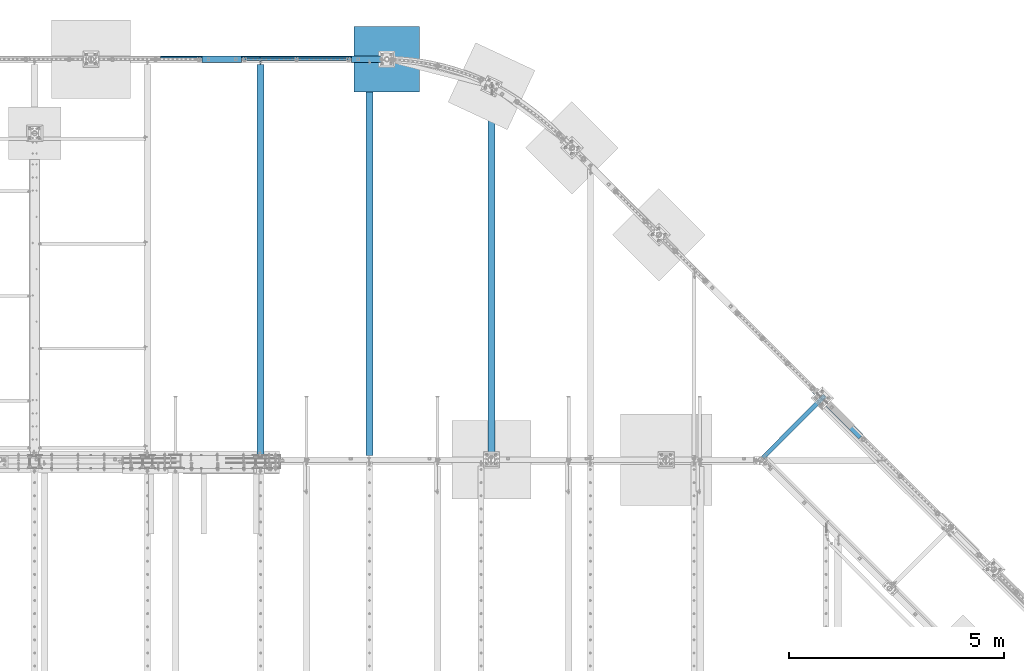
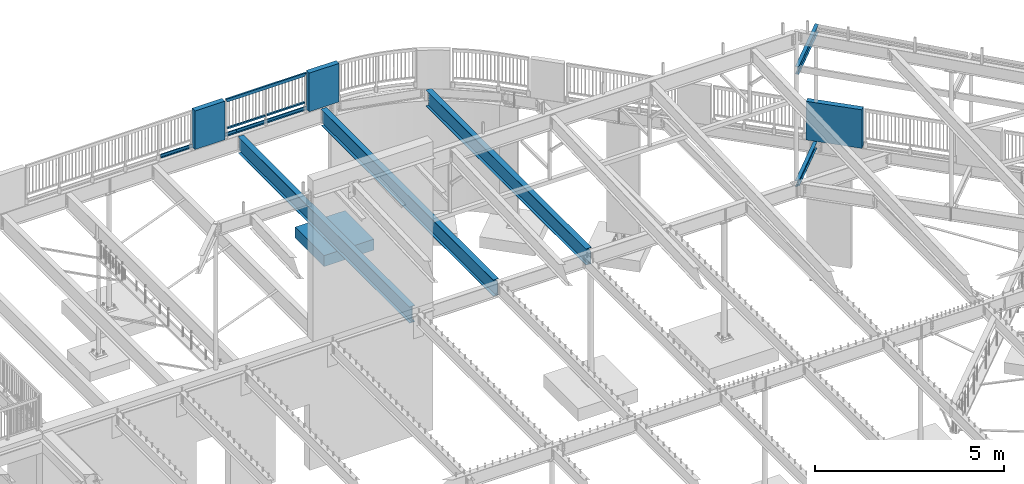
# One storey, part 327 of 975: 14 beams.
"""IFC2X3 building model written with IfcOpenShell, lengths in millimetres."""

from ifc_helpers import new_model, si_unit, frame, origin_with_axes, place, context, subcontext, project, spatial, faceted_brep, material, type_object, element, save


model = new_model("IFC2X3")

# Units and contexts
model_context = context("Model", 3, precision=1e-05, world=origin_with_axes())
body_context = subcontext(model_context, "Body", "Model", "MODEL_VIEW")
ifc_project = project(units=[si_unit("LENGTHUNIT", "METRE", prefix="MILLI"), si_unit("AREAUNIT", "SQUARE_METRE"), si_unit("VOLUMEUNIT", "CUBIC_METRE"), si_unit("MASSUNIT", "GRAM", prefix="KILO"), si_unit("TIMEUNIT", "SECOND"), si_unit("PLANEANGLEUNIT", "RADIAN"), si_unit("SOLIDANGLEUNIT", "STERADIAN"), si_unit("THERMODYNAMICTEMPERATUREUNIT", "DEGREE_CELSIUS"), si_unit("LUMINOUSINTENSITYUNIT", "LUMEN")], contexts=[model_context])

# Site, building, storey
site_placement = place(None, origin_with_axes())
site = spatial("IfcSite", under=ifc_project, at=site_placement, CompositionType="ELEMENT")
building_placement = place(site_placement, origin_with_axes())
building = spatial("IfcBuilding", under=site, at=building_placement, Name="Undefined", CompositionType="ELEMENT")
storey_placement = place(building_placement, origin_with_axes())
storey = spatial("IfcBuildingStorey", under=building, at=storey_placement, Name="Undefined", CompositionType="ELEMENT", Elevation=0.0)

# Beams
ifc_material_1 = material()
beam_type_1 = type_object("IfcBeamType", Name="HSS2X2X.188_TUBES", PredefinedType="NOTDEFINED")
beam_1_placement = place(storey_placement, frame((14322.4237406584, 29962.8265326967, 4229.09979190979), z_axis=(4.55899999906251e-06, 0.999999999989608, 0.0), x_axis=(0.999999999989593, -4.55899999895318e-06, 1.72999999958954e-07)))
element("IfcBeam", 1, at=beam_1_placement, inside=storey, type_object=beam_type_1, material=ifc_material_1, Name="HANDRAIL", ObjectType="HSS2X2X.188_TUBES", context=body_context, shape_type="Brep", body=[
    faceted_brep([(25.4001425128263, 20.6374999999998, -20.6375000000021), (25.4001990651432, -20.6375000000071, -20.6374999999789), (1181.10572182246, -20.6375000003245, -20.6374999983891), (1181.10571224662, 20.637499999676, -20.6374999983454), (25.4000002641624, -20.6375000000153, 20.6374999999998), (1181.10572182253, -20.6375000003245, 20.6375000015905), (25.3999997357314, 20.6374999999898, 20.6374999999998), (1181.10571224669, 20.637499999676, 20.6375000016342), (25.4001717116989, 25.3999999999996, -25.4000000000026), (25.3999456287493, 25.3999999999942, 25.4000000000487), (1181.1057111418, 25.3999999996768, 25.4000000016385), (1181.1057111417, 25.3999999996768, -25.3999999983353), (25.4000003251349, -25.4000000000124, 25.3999999999996), (1181.10572292744, -25.4000000003252, 25.400000001584), (25.4002252827013, -25.4000000000078, -25.3999999999796), (1181.10572292735, -25.4000000003252, -25.3999999983898)], [[[0, 1, 2, 3]], [[1, 4, 5, 2]], [[4, 6, 7, 5]], [[6, 0, 3, 7]], [[8, 9, 10, 11]], [[9, 12, 13, 10]], [[12, 14, 15, 13]], [[14, 8, 11, 15]], [[13, 15, 11, 10], [5, 7, 3, 2]], [[14, 12, 9, 8], [6, 4, 1, 0]]]),
])
beam_2_placement = place(storey_placement, frame((13115.9195843186, 29962.8320325627, 4229.10021523314), z_axis=(4.55899999906251e-06, 0.999999999989608, 0.0), x_axis=(0.999999999989593, -4.55899999895318e-06, 1.72999999958954e-07)))
element("IfcBeam", 2, at=beam_2_placement, inside=storey, type_object=beam_type_1, material=ifc_material_1, Name="HANDRAIL", ObjectType="HSS2X2X.188_TUBES", context=body_context, shape_type="Brep", body=[
    faceted_brep([(25.4001425128263, 20.6374999999998, -20.6375000000021), (25.4001244344508, -20.6375000000044, -20.6375000000025), (1181.10434338417, -20.6374999995523, -20.6374999983309), (1181.10432840139, 20.6375000004518, -20.6374999983964), (25.3998894558863, -20.6375000000044, 20.6375), (1181.10415521153, -20.6374999995523, 20.6375000016487), (25.3999075342581, 20.6374999999998, 20.6375000000003), (1181.10414022874, 20.6375000004509, 20.6375000015832), (25.4001717116989, 25.3999999999996, -25.4000000000026), (25.3998825073104, 25.4000000000005, 25.4000000000005), (1181.10411678772, 25.4000000004507, 25.4000000015731), (1181.10434838483, 25.4000000004507, -25.3999999984007), (25.3998602570064, -25.4000000000033, 25.4000000000001), (1181.10413522808, -25.3999999995522, 25.4000000016531), (25.4001494613913, -25.4000000000042, -25.4000000000028), (1181.10436682519, -25.3999999995513, -25.3999999983207)], [[[0, 1, 2, 3]], [[1, 4, 5, 2]], [[4, 6, 7, 5]], [[6, 0, 3, 7]], [[8, 9, 10, 11]], [[9, 12, 13, 10]], [[12, 14, 15, 13]], [[14, 8, 11, 15]], [[13, 15, 11, 10], [5, 7, 3, 2]], [[14, 12, 9, 8], [6, 4, 1, 0]]]),
])
beam_type_2 = type_object("IfcBeamType", Name="HSS2X4X.188_TUBES", PredefinedType="NOTDEFINED")
beam_3_placement = place(storey_placement, frame((13115.9195945456, 29962.9345599569, 5130.7999999893), z_axis=(0.0, 0.0, 1.0), x_axis=(0.999999998764607, -4.97069999879304e-05, -1.40000005822416e-08)))
element("IfcBeam", 3, at=beam_3_placement, inside=storey, type_object=beam_type_2, material=ifc_material_1, Name="GUARDRAIL", ObjectType="HSS2X4X.188_TUBES", context=body_context, shape_type="Brep", body=[
    faceted_brep([(23.0198915490837, 20.6374999999994, -46.0375000000031), (23.0198915283145, -20.6374999999966, -46.0375000000085), (2389.989866368, -20.6375000042644, -46.0375000007098), (2389.98986636787, 20.6374999957989, -46.0375000007043), (-23.0198845522937, -20.6374999999985, 46.0375000000058), (2436.02963182534, -20.6375000043445, 46.0374999992773), (-23.0198845315244, 20.6374999999973, 46.0375000000113), (2436.0296318252, 20.6374999957188, 46.0374999992819), (25.4012592797953, 25.399999999999, -50.8000000000029), (-25.4012522574303, 25.3999999999967, 50.800000000012), (2438.41099900402, 25.3999999957196, 50.7999999992817), (2387.60849918903, 25.3999999958105, -50.8000000007032), (-25.401252282998, -25.3999999999983, 50.8000000000056), (2438.41099900418, -25.4000000043598, 50.7999999992753), (25.401259254224, -25.399999999996, -50.8000000000102), (2387.60849918919, -25.4000000042652, -50.8000000007096)], [[[0, 1, 2, 3]], [[1, 4, 5, 2]], [[4, 6, 7, 5]], [[6, 0, 3, 7]], [[8, 9, 10, 11]], [[9, 12, 13, 10]], [[12, 14, 15, 13]], [[14, 8, 11, 15]], [[13, 15, 11, 10], [5, 7, 3, 2]], [[14, 12, 9, 8], [6, 4, 1, 0]]]),
])
ifc_material_2 = material(Name="STEEL/A36")
beam_type_3 = type_object("IfcBeamType", PredefinedType="NOTDEFINED")
for number, where, z_axis, x_axis, name in (
    (4, (14995.0081018703, 29987.8750007629, 3938.58749694824), (1.0, 0.0, 0.0), (0.0, 1.0, 0.0), "DECK_EDGE"),
    (5, (12684.2034148703, 29987.8750007629, 3938.58749694824), (1.0, 0.0, 0.0), (0.0, 1.0, 0.0), "DECK_EDGE"),
):
    element("IfcBeam", number, at=place(storey_placement, frame(where, z_axis=z_axis, x_axis=x_axis)), inside=storey, type_object=beam_type_3, material=ifc_material_2, Name=name, context=body_context, shape_type="Brep", body=[
        faceted_brep([(1.03318598121405e-09, -1.58750000000009, -1524.00000000109), (-1.04046193882823e-09, -1.58750000000009, 1524.0000000011), (-1.04046193882823e-09, 1.58750000000009, 1524.0000000011), (1.03318598121405e-09, 1.58750000000009, -1524.00000000109), (47.6250001214066, 1.58750000000009, 1524.00000000113), (47.6250001235167, 1.58750000000009, -1524.00000000107), (50.8000001235196, -1.58750000000009, -1524.00000000106), (50.8000001214168, -1.58750000000009, 1524.00000000113), (47.6250001214503, 96.837499999901, 1524.00000000113), (47.625000123473, 96.8374999999951, -1524.00000000106), (50.8000001234759, 104.502628762961, -1524.00000000106), (50.8000001214605, 104.502628762867, 1524.00000000113), (38.6447461584321, 87.8572448731024, 1524.00000000113), (38.6447461604548, 87.8572448731024, -1524.00000000107), (36.3996819826862, 90.102308757891, 1524.00000000112), (36.3996819847016, 90.102308757891, -1524.00000000107)], [[[0, 1, 2, 3]], [[3, 2, 4, 5]], [[1, 0, 6, 7]], [[5, 4, 8, 9]], [[7, 6, 10, 11]], [[9, 8, 12, 13]], [[8, 4, 2, 1, 7, 11, 14, 12]], [[11, 10, 15, 14]], [[10, 6, 0, 3, 5, 9, 13, 15]], [[14, 15, 13, 12]]]),
    ])
ifc_material_3 = material(Name="CONCRETE/5000")
beam_type_4 = type_object("IfcBeamType", PredefinedType="NOTDEFINED")
beam_4_placement = place(storey_placement, frame((26379.2367208331, 22255.5767762607, 4559.3), z_axis=(0.0, 0.0, 1.0), x_axis=(0.707901544041155, -0.706311124041062, 0.0)))
element("IfcBeam", 6, at=beam_4_placement, inside=storey, type_object=beam_type_4, material=ifc_material_3, Name="LOW WALL", context=body_context, shape_type="Brep", body=[
    faceted_brep([(1.0550138540566e-10, 76.1999999999316, -622.3), (1.0550138540566e-10, 76.1999999999316, 622.3), (1523.99999999965, 76.1999999968903, 622.3), (1523.99999999965, 76.1999999968903, -622.3), (-1.01863406598568e-10, -76.1999999999243, 622.3), (1523.99999999934, -76.2000000030603, 622.3), (-1.01863406598568e-10, -76.1999999999243, -622.3), (1523.99999999934, -76.2000000030603, -622.3)], [[[0, 1, 2, 3]], [[1, 4, 5, 2]], [[4, 6, 7, 5]], [[6, 0, 3, 7]], [[5, 7, 3, 2]], [[6, 4, 1, 0]]]),
])
for number, where, z_axis, x_axis, name in (
    (7, (15604.6767760911, 29962.4750010581, 4559.3), (0.0, 0.0, 1.0), (1.0, 0.0, 0.0), "LOW WALL"),
    (8, (12124.8767760911, 29962.4749999424, 4559.3), (0.0, 0.0, 1.0), (1.0, 0.0, 0.0), "LOW WALL"),
):
    element("IfcBeam", number, at=place(storey_placement, frame(where, z_axis=z_axis, x_axis=x_axis)), inside=storey, type_object=beam_type_4, material=ifc_material_3, Name=name, context=body_context, shape_type="Brep", body=[
        faceted_brep([(1.0550138540566e-10, 76.1999999999316, -622.3), (1.0550138540566e-10, 76.1999999999316, 622.3), (914.399999999998, 76.1999999999998, 622.3), (914.399999999998, 76.1999999999998, -622.3), (-1.01863406598568e-10, -76.1999999999243, 622.3), (914.399999999998, -76.2, 622.3), (-1.01863406598568e-10, -76.1999999999243, -622.3), (914.399999999998, -76.2, -622.3)], [[[0, 1, 2, 3]], [[1, 4, 5, 2]], [[4, 6, 7, 5]], [[6, 0, 3, 7]], [[5, 7, 3, 2]], [[6, 4, 1, 0]]]),
    ])
ifc_material_4 = material(Name="STEEL/A992")
beam_type_5 = type_object("IfcBeamType", Name="W8X10", PredefinedType="NOTDEFINED")
beam_5_placement = place(storey_placement, frame((25101.7589783175, 20621.7350997173, 3836.9875), z_axis=(0.0, 0.0, 1.0), x_axis=(0.706311124041062, 0.707901544041155, 0.0)))
element("IfcBeam", 9, at=beam_5_placement, inside=storey, type_object=beam_type_5, material=ifc_material_4, Name="BEAM", ObjectType="W8X10", context=body_context, shape_type="Brep", body=[
    faceted_brep([(176.268304754849, -50.8000000003403, -95.25), (176.268304754849, -50.8000000003403, -100.0125), (1975.89221346932, -50.8000000039819, -100.0125), (1975.89221346932, -50.8000000039819, -95.25), (127.958335628362, -2.38125000025957, -95.25), (1975.89221346932, -2.38125000400123, -95.25), (127.958335628362, -2.38125000025957, 95.25), (1975.89221346932, -2.38125000400123, 95.25), (176.268304754849, -50.8000000003403, 95.25), (1975.89221346932, -50.8000000039819, 95.25), (176.268304754849, -50.8000000003403, 100.0125), (1975.89221346932, -50.8000000039819, 100.0125), (74.8965662599221, 50.7999999998292, 100.0125), (1975.89221346932, 50.799999995982, 100.0125), (74.8965662599221, 50.7999999998292, 95.25), (1975.89221346932, 50.799999995982, 95.25), (123.206535386409, 2.38124999974843, 95.25), (1975.89221346931, 2.3812499959995, 95.25), (123.206535386409, 2.38124999974843, -95.25), (1975.89221346931, 2.3812499959995, -95.25), (74.8965662599221, 50.7999999998292, -95.25), (1975.89221346932, 50.799999995982, -95.25), (74.8965662599221, 50.7999999998292, -100.0125), (1975.89221346932, 50.799999995982, -100.0125)], [[[0, 1, 2, 3]], [[4, 0, 3, 5]], [[6, 4, 5, 7]], [[8, 6, 7, 9]], [[10, 8, 9, 11]], [[12, 10, 11, 13]], [[14, 12, 13, 15]], [[16, 14, 15, 17]], [[18, 16, 17, 19]], [[20, 18, 19, 21]], [[1, 0, 4, 6, 8, 10, 12, 14, 16, 18, 20, 22]], [[1, 22, 23, 2]], [[19, 17, 15, 13, 11, 9, 7, 5, 3, 2, 23, 21]], [[22, 20, 21, 23]]]),
])
beam_type_6 = type_object("IfcBeamType", Name="W10X12", PredefinedType="NOTDEFINED")
beam_6_placement = place(storey_placement, frame((25126.9920609686, 20647.025, 7494.5875), z_axis=(0.0, 0.0, 1.0), x_axis=(0.706311124041062, 0.707901544041155, 0.0)))
element("IfcBeam", 10, at=beam_6_placement, inside=storey, type_object=beam_type_6, material=ifc_material_4, Name="BEAM", ObjectType="W10X12", context=body_context, shape_type="Brep", body=[
    faceted_brep([(69.14642435938, -50.8000000001248, -120.65), (69.14642435938, -50.8000000001248, -125.4125), (2105.30102741388, -50.8000000042503, -125.4125), (2105.30102741388, -50.8000000042503, -120.65), (69.14642435938, -2.38125000014224, -120.65), (2105.30102741398, -2.38125000426226, -120.65), (69.14642435938, -2.38125000014224, 120.65), (2105.30102741398, -2.38125000426226, 120.65), (69.14642435938, -50.8000000001248, 120.65), (2105.30102741388, -50.8000000042503, 120.65), (69.14642435938, -50.8000000001248, 125.4125), (2105.30102741388, -50.8000000042503, 125.4125), (69.14642435938, 50.799999999841, 125.4125), (2105.30102741408, 50.7999999957192, 125.4125), (69.14642435938, 50.799999999841, 120.65), (2105.30102741408, 50.7999999957192, 120.65), (69.14642435938, 2.3812499998603, 120.65), (2105.30102741399, 2.3812499957312, 120.65), (69.14642435938, 2.3812499998603, -120.65), (2105.30102741399, 2.3812499957312, -120.65), (69.14642435938, 50.799999999841, -120.65), (2105.30102741408, 50.7999999957192, -120.65), (69.14642435938, 50.799999999841, -125.4125), (2105.30102741408, 50.7999999957192, -125.4125)], [[[0, 1, 2, 3]], [[4, 0, 3, 5]], [[6, 4, 5, 7]], [[8, 6, 7, 9]], [[10, 8, 9, 11]], [[12, 10, 11, 13]], [[14, 12, 13, 15]], [[16, 14, 15, 17]], [[18, 16, 17, 19]], [[20, 18, 19, 21]], [[1, 0, 4, 6, 8, 10, 12, 14, 16, 18, 20, 22]], [[1, 22, 23, 2]], [[19, 17, 15, 13, 11, 9, 7, 5, 3, 2, 23, 21]], [[22, 20, 21, 23]]]),
])
beam_type_7 = type_object("IfcBeamType", PredefinedType="NOTDEFINED")
beam_7_placement = place(storey_placement, frame((15662.2750084657, 29962.475023622, -482.6), z_axis=(0.0, 0.0, 1.0), x_axis=(1.0, 0.0, 0.0)))
element("IfcBeam", 11, at=beam_7_placement, inside=storey, type_object=beam_type_7, material=ifc_material_3, Name="FOOTING", context=body_context, shape_type="Brep", body=[
    faceted_brep([(4.8748916015029e-10, 762.000000001049, -177.8), (4.8748916015029e-10, 762.000000001049, 177.8), (1524.00000000259, 762.000000000074, 177.8), (1524.00000000259, 762.000000000074, -177.8), (-4.80213202536106e-10, -762.000000001047, 177.8), (1524.00000000162, -762.00000000202, 177.8), (-4.80213202536106e-10, -762.000000001047, -177.8), (1524.00000000162, -762.00000000202, -177.8)], [[[0, 1, 2, 3]], [[1, 4, 5, 2]], [[4, 6, 7, 5]], [[6, 0, 3, 7]], [[5, 7, 3, 2]], [[6, 4, 1, 0]]]),
])
beam_type_8 = type_object("IfcBeamType", Name="W21X44", PredefinedType="NOTDEFINED")
beam_8_placement = place(storey_placement, frame((16021.05, 20621.7350997173, 3675.0625), z_axis=(0.0, 0.0, 1.0), x_axis=(0.0, 1.0, 0.0)))
element("IfcBeam", 12, at=beam_8_placement, inside=storey, type_object=beam_type_8, material=ifc_material_4, Name="BEAM", ObjectType="W21X44", context=body_context, shape_type="Brep", body=[
    faceted_brep([(9202.62740028273, -4.76250000000073, -250.825), (9202.62740028273, -82.5499999999993, -250.825), (9202.62740028273, -82.5499999999993, -261.9375), (9202.62740028273, 82.5499999999993, -261.9375), (9202.62740028273, 82.5499999999993, -250.825), (9202.62740028273, 4.76250000000073, -250.825), (9202.62740028273, 4.76250000000073, -249.237499809265), (9202.62740028273, -4.76250000000073, -249.237499809265), (9203.59413020532, 4.76250000000073, -244.37742029122), (9203.59413020532, -4.76250000000073, -244.37742029122), (9206.3471441058, 4.76250000000073, -240.257243823066), (9206.3471441058, -4.76250000000073, -240.257243823066), (9210.46732057395, 4.76250000000073, -237.504229922588), (9210.46732057395, -4.76250000000073, -237.504229922588), (9215.327400092, 4.76250000000073, -236.5375), (9215.327400092, -4.76250000000073, -236.5375), (9304.22740028273, -4.76250000000073, -236.5375), (9304.22740028273, 4.76250000000073, -236.5375), (9208.97740028273, 4.76250000000073, 250.825), (118.268750000007, 4.76250000000073, 250.825), (118.268750000007, 82.5499999999993, 250.825), (9208.97740028273, 82.5499999999993, 250.825), (9215.32740028273, 82.5499999999993, 250.825), (9215.32740028273, 4.76250000000073, 250.825), (118.268750000007, -4.76250000000073, -179.387499809266), (118.268750000007, 4.76250000000073, -179.387499809266), (118.268750000007, 4.76250000000073, -250.825), (118.268750000007, 82.5499999999993, -250.825), (118.268750000007, 82.5499999999993, -261.9375), (118.268750000007, -82.5499999999993, -261.9375), (118.268750000007, -82.5499999999993, -250.825), (118.268750000007, -4.76250000000073, -250.825), (117.302020077419, -4.76250000000073, -174.527420291221), (117.302020077419, 4.76250000000073, -174.527420291221), (114.549006176941, -4.76250000000073, -170.407243823067), (114.549006176941, 4.76250000000073, -170.407243823067), (110.428829708788, -4.76250000000073, -167.654229922589), (110.428829708788, 4.76250000000073, -167.654229922589), (105.568750190741, -4.76250000000073, -166.687500000001), (105.568750190741, 4.76250000000073, -166.687500000001), (29.3687500000015, -4.76250000000073, -166.687500000001), (29.3687500000015, 4.76250000000073, -166.687500000001), (29.3687500000015, -4.76250000000073, 236.537499999999), (29.3687500000015, 4.76250000000073, 236.537499999999), (105.568750190741, -4.76250000000073, 236.537499999999), (105.568750190741, 4.76250000000073, 236.537499999999), (110.428829708788, -4.76250000000073, 237.504229922587), (110.428829708788, 4.76250000000073, 237.504229922587), (114.549006176941, -4.76250000000073, 240.257243823065), (114.549006176941, 4.76250000000073, 240.257243823065), (117.302020077419, -4.76250000000073, 244.377420291219), (117.302020077419, 4.76250000000073, 244.377420291219), (118.268750000007, -4.76250000000073, 249.237499809264), (118.268750000007, 4.76250000000073, 249.237499809264), (118.268750000007, -82.5499999999993, 261.937499810058), (118.268750000007, 82.5499999999993, 261.9375), (118.268750000007, -4.76250000000073, 250.825), (118.268750000007, -82.5499999999993, 250.825), (9215.32740028273, -4.76250000000073, 250.825), (9215.32740028273, -82.5499999999993, 250.825), (9215.32740028273, -82.5499999999993, 261.937499999339), (9215.32740028273, 82.5499999999993, 261.9375), (9215.32740028273, -4.76250000000073, 249.237499809265), (9215.32740028273, 4.76250000000073, 249.237499809265), (9216.29413020532, -4.76250000000073, 244.37742029122), (9216.29413020532, 4.76250000000073, 244.37742029122), (9219.04714410579, -4.76250000000073, 240.257243823066), (9219.04714410579, 4.76250000000073, 240.257243823066), (9223.16732057395, -4.76250000000073, 237.504229922588), (9223.16732057395, 4.76250000000073, 237.504229922588), (9228.02740009199, -4.76250000000073, 236.5375), (9228.02740009199, 4.76250000000073, 236.5375), (9304.22740028273, -4.76250000000073, 236.5375), (9304.22740028273, 4.76250000000073, 236.5375)], [[[0, 1, 2, 3, 4, 5, 6, 7]], [[7, 6, 8, 9]], [[9, 8, 10, 11]], [[11, 10, 12, 13]], [[13, 12, 14, 15]], [[16, 15, 14, 17]], [[18, 19, 20, 21, 22, 23]], [[24, 25, 26, 27, 28, 29, 30, 31]], [[32, 33, 25, 24]], [[34, 35, 33, 32]], [[36, 37, 35, 34]], [[38, 39, 37, 36]], [[40, 41, 39, 38]], [[42, 43, 41, 40]], [[44, 45, 43, 42]], [[46, 47, 45, 44]], [[48, 49, 47, 46]], [[50, 51, 49, 48]], [[52, 53, 51, 50]], [[54, 55, 20, 19, 53, 52, 56, 57]], [[57, 56, 58, 59]], [[54, 57, 59, 60]], [[55, 54, 60, 61]], [[21, 20, 55, 61, 22]], [[60, 59, 58, 62, 63, 23, 22, 61]], [[64, 65, 63, 62]], [[66, 67, 65, 64]], [[68, 69, 67, 66]], [[70, 71, 69, 68]], [[72, 73, 71, 70]], [[73, 72, 16, 17]], [[12, 10, 8, 6, 5, 26, 25, 33, 35, 37, 39, 41, 43, 45, 47, 49, 51, 53, 19, 18, 23, 63, 65, 67, 69, 71, 73, 17, 14]], [[27, 26, 5, 4]], [[28, 27, 4, 3]], [[29, 28, 3, 2]], [[30, 29, 2, 1]], [[31, 30, 1, 0]], [[72, 70, 68, 66, 64, 62, 58, 56, 52, 50, 48, 46, 44, 42, 40, 38, 36, 34, 32, 24, 31, 0, 7, 9, 11, 13, 15, 16]]]),
])
beam_9_placement = place(storey_placement, frame((18859.5, 20621.7350997173, 3675.0625), z_axis=(0.0, 0.0, 1.0), x_axis=(0.0, 1.0, 0.0)))
element("IfcBeam", 13, at=beam_9_placement, inside=storey, type_object=beam_type_8, material=ifc_material_4, Name="BEAM", ObjectType="W21X44", context=body_context, shape_type="Brep", body=[
    faceted_brep([(8598.08509395955, -52.0593321564338, 261.9375), (8566.58476230473, -82.5499999999993, 261.937499999295), (8566.58476230473, -82.5499999999993, 250.825), (8598.08509395955, -52.0593321564338, 250.825), (8598.08509395955, 82.5499999999993, 250.825), (8598.08509395955, 4.76250000000073, 250.825), (135.731250000004, 4.76250000000073, 250.825), (135.731250000004, 82.5499999999993, 250.825), (135.731250000004, -4.76250000000073, 249.237499809264), (135.731250000004, 4.76250000000073, 249.237499809264), (134.764520077417, 4.76250000000073, 244.377420291219), (134.764520077417, -4.76250000000073, 244.377420291219), (132.011506176939, 4.76250000000073, 240.257243823065), (132.011506176939, -4.76250000000073, 240.257243823065), (127.891329708786, 4.76250000000073, 237.504229922587), (127.891329708786, -4.76250000000073, 237.504229922587), (123.031250190739, 4.76250000000073, 236.537499999999), (123.031250190739, -4.76250000000073, 236.537499999999), (24.6062500000007, 4.76250000000073, 236.537499999999), (24.6062500000007, -4.76250000000073, 236.537499999999), (24.6062500000007, 4.76250000000073, -160.337500000001), (24.6062500000007, -4.76250000000073, -160.337500000001), (123.031250190739, 4.76250000000073, -160.337500000001), (123.031250190739, -4.76250000000073, -160.337500000001), (127.891329708786, 4.76250000000073, -161.304229922589), (127.891329708786, -4.76250000000073, -161.304229922589), (132.011506176939, 4.76250000000073, -164.057243823067), (132.011506176939, -4.76250000000073, -164.057243823067), (134.764520077417, 4.76250000000073, -168.177420291221), (134.764520077417, -4.76250000000073, -168.177420291221), (135.731250000004, 4.76250000000073, -173.037499809266), (135.731250000004, -4.76250000000073, -173.037499809266), (8598.08509395955, 4.76250000000073, -250.825), (135.731250000004, 4.76250000000073, -250.825), (8598.08509395955, 82.5499999999993, -250.825), (135.731250000004, 82.5499999999993, -250.825), (8598.08509395955, 82.5499999999993, -261.9375), (135.731250000004, 82.5499999999993, -261.9375), (8598.08509395955, -82.5499999999993, -261.9375), (135.731250000004, -82.5499999999993, -261.9375), (8598.08509395955, -82.5499999999993, -250.825), (135.731250000004, -82.5499999999993, -250.825), (8598.08509395955, -4.76250000000073, -250.825), (135.731250000004, -4.76250000000073, -250.825), (8598.08509395955, -4.76250000000073, 250.825), (135.731250000004, -4.76250000000073, 250.825), (135.731250000004, -82.5499999999993, 261.937499810474), (135.731250000004, 82.5499999999993, 261.9375), (135.731250000004, -82.5499999999993, 250.825), (8598.08509395955, 82.5499999999993, 261.9375)], [[[0, 1, 2, 3]], [[4, 5, 6, 7]], [[8, 9, 10, 11]], [[11, 10, 12, 13]], [[13, 12, 14, 15]], [[15, 14, 16, 17]], [[17, 16, 18, 19]], [[19, 18, 20, 21]], [[21, 20, 22, 23]], [[23, 22, 24, 25]], [[25, 24, 26, 27]], [[27, 26, 28, 29]], [[29, 28, 30, 31]], [[26, 24, 22, 20, 18, 16, 14, 12, 10, 9, 6, 5, 32, 33, 30, 28]], [[32, 34, 35, 33]], [[34, 36, 37, 35]], [[36, 38, 39, 37]], [[38, 40, 41, 39]], [[40, 42, 43, 41]], [[31, 30, 33, 35, 37, 39, 41, 43]], [[42, 44, 45, 8, 11, 13, 15, 17, 19, 21, 23, 25, 27, 29, 31, 43]], [[46, 47, 7, 6, 9, 8, 45, 48]], [[49, 4, 7, 47]], [[44, 42, 40, 38, 36, 34, 32, 5, 4, 49, 0, 3]], [[48, 45, 44, 3, 2]], [[46, 48, 2, 1]], [[49, 47, 46, 1, 0]]]),
])
beam_10_placement = place(storey_placement, frame((13487.4, 20748.625, 3675.0625), z_axis=(0.0, 0.0, 1.0), x_axis=(0.0, 1.0, 0.0)))
element("IfcBeam", 14, at=beam_10_placement, inside=storey, type_object=beam_type_8, material=ifc_material_4, Name="BEAM", ObjectType="W21X44", context=body_context, shape_type="Brep", body=[
    faceted_brep([(9177.3375, -4.76250000000073, 236.5375), (9177.3375, 4.76250000000073, 236.5375), (9101.13749980927, 4.76250000000073, 236.5375), (9101.13749980927, -4.76250000000073, 236.5375), (9096.27742029122, 4.76250000000073, 237.504229922588), (9096.27742029122, -4.76250000000073, 237.504229922588), (9092.15724382307, 4.76250000000073, 240.257243823066), (9092.15724382307, -4.76250000000073, 240.257243823066), (9089.40422992259, 4.76250000000073, 244.37742029122), (9089.40422992259, -4.76250000000073, 244.37742029122), (9088.4375, 4.76250000000073, 249.237499809265), (9088.4375, -4.76250000000073, 249.237499809265), (25.4000000000015, -82.5499999999993, 250.825), (25.4000000000015, -4.76250000000073, 250.825), (9088.4375, -4.76250000000073, 250.825), (9088.4375, -82.5499999999993, 250.825), (25.4000000000015, -82.5499999999993, 261.9375), (9088.4375, -82.5499999999993, 261.9375), (25.4000000000015, 82.5499999999993, 261.9375), (9088.4375, 82.5499999999993, 261.9375), (9082.0875, 82.5499999999993, 250.825), (25.4000000000015, 82.5499999999993, 250.825), (9088.4375, 82.5499999999993, 250.825), (9088.4375, 4.76250000000073, 250.825), (9082.0875, 4.76250000000073, 250.825), (25.4000000000015, 4.76250000000073, 250.825), (25.4000000000015, -82.5499999999993, -261.9375), (25.4000000000015, -82.5499999999993, -250.825), (25.4000000000015, -4.76250000000073, -250.825), (25.4000000000015, 4.76250000000073, -250.825), (25.4000000000015, 82.5499999999993, -250.825), (25.4000000000015, 82.5499999999993, -261.9375), (9075.7375, 4.76250000000073, -250.825), (9075.7375, 82.5499999999993, -250.825), (9075.7375, 82.5499999999993, -261.9375), (9075.7375, -82.5499999999993, -261.9375), (9075.7375, -82.5499999999993, -250.825), (9075.7375, -4.76250000000073, -250.825), (9075.7375, -4.76250000000073, -249.237499809265), (9076.70422992259, -4.76250000000073, -244.37742029122), (9079.45724382307, -4.76250000000073, -240.257243823066), (9083.57742029122, -4.76250000000073, -237.504229922588), (9088.43749980927, -4.76250000000073, -236.5375), (9177.3375, -4.76250000000073, -236.5375), (9177.3375, 4.76250000000073, -236.5375), (9083.57742029122, 4.76250000000073, -237.504229922588), (9079.45724382307, 4.76250000000073, -240.257243823066), (9076.70422992259, 4.76250000000073, -244.37742029122), (9075.7375, 4.76250000000073, -249.237499809265), (9088.43749980927, 4.76250000000073, -236.5375)], [[[0, 1, 2, 3]], [[3, 2, 4, 5]], [[5, 4, 6, 7]], [[7, 6, 8, 9]], [[9, 8, 10, 11]], [[12, 13, 14, 15]], [[16, 12, 15, 17]], [[18, 16, 17, 19]], [[20, 21, 18, 19, 22]], [[17, 15, 14, 11, 10, 23, 22, 19]], [[24, 25, 21, 20, 22, 23]], [[26, 27, 28, 13, 12, 16, 18, 21, 25, 29, 30, 31]], [[30, 29, 32, 33]], [[31, 30, 33, 34]], [[26, 31, 34, 35]], [[27, 26, 35, 36]], [[28, 27, 36, 37]], [[0, 3, 5, 7, 9, 11, 14, 13, 28, 37, 38, 39, 40, 41, 42, 43]], [[1, 0, 43, 44]], [[45, 46, 47, 48, 32, 29, 25, 24, 23, 10, 8, 6, 4, 2, 1, 44, 49]], [[43, 42, 49, 44]], [[41, 45, 49, 42]], [[40, 46, 45, 41]], [[39, 47, 46, 40]], [[38, 48, 47, 39]], [[37, 36, 35, 34, 33, 32, 48, 38]]]),
])

save(model, "model.ifc")
